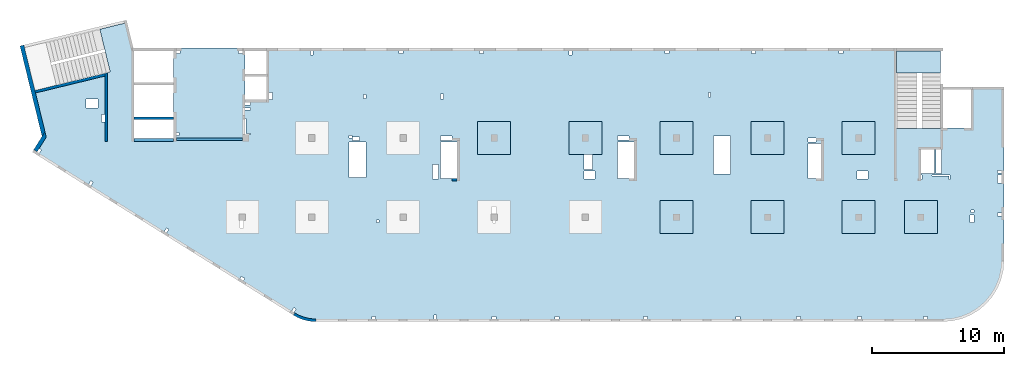
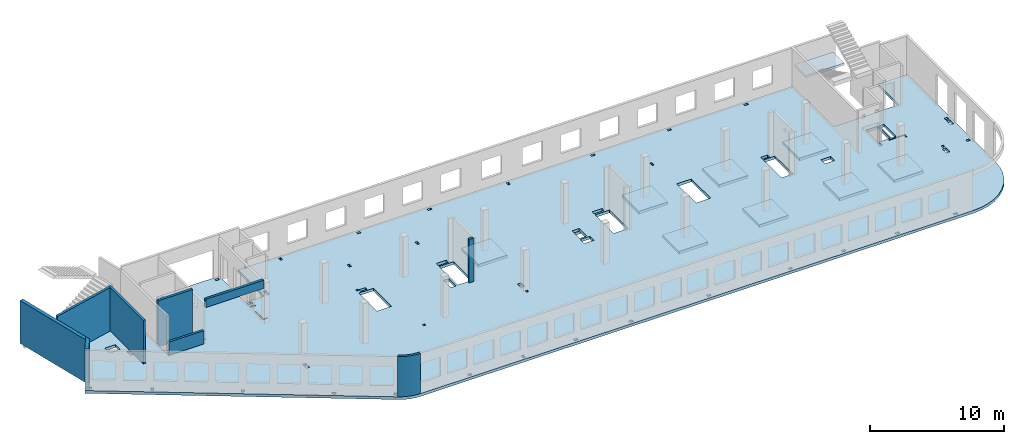
# One storey, part 2 of 6: 11 slabs, 9 walls.
"""IFC4 building model written with IfcOpenShell, lengths in millimetres."""

import ifcopenshell
import ifcopenshell.guid

model = None  # the IFC model being written
_history = None  # IfcOwnerHistory: only IFC2X3 demands one
_inside = {}  # id of a spatial element -> (the spatial element, [elements in it])
_under = {}  # id of a project, library or spatial element -> (it, [spatial elements below it])
_declared = {}  # id of a project -> (the project, [libraries it declares])
_typed = {}  # id of a type object -> (the type object, [elements of that type])
_made_of = {}  # id of a material, layer set ... -> (it, [elements and type objects made of it])


def new_model(schema):
    """Start an empty IFC model of exactly this schema.

    Asked for "IFC4X3", IfcOpenShell would pick the latest addendum, in which some entities
    have other attributes; the version numbers below select the first issue.
    IFC2X3 requires an IfcOwnerHistory on every rooted entity: one is made here for all.
    """
    global model, _history
    if schema == "IFC4X3":
        model = ifcopenshell.file(schema_version=(4, 3, 0, 0))
    else:
        model = ifcopenshell.file(schema=schema)
    _inside.clear()
    _under.clear()
    _declared.clear()
    _typed.clear()
    _made_of.clear()
    _history = None
    if model.schema == "IFC2X3":
        org = make("IfcOrganization", Name="unknown")
        user = make(
            "IfcPersonAndOrganization",
            ThePerson=make("IfcPerson", FamilyName="unknown"),
            TheOrganization=org,
        )
        app = make(
            "IfcApplication",
            ApplicationDeveloper=org,
            Version="unknown",
            ApplicationFullName="unknown",
            ApplicationIdentifier="unknown",
        )
        _history = make(
            "IfcOwnerHistory",
            OwningUser=user,
            OwningApplication=app,
            ChangeAction="ADDED",
            CreationDate=0,
        )
    return model


def make(cls, **values):
    """One entity of the class cls with the attributes given. An attribute that is None is left unset."""
    return model.create_entity(
        cls, **{name: value for name, value in values.items() if value is not None}
    )


def entity(cls, *values):
    """Any entity or typed value of the class cls, its attributes in the order of the schema. None: left unset."""
    e = model.create_entity(cls)
    for i, value in enumerate(values):
        if value is not None:
            e[i] = value
    return e


def rooted(cls, **values):
    """An entity with a GlobalId (a new one), such as an element, a storey or a relation."""
    return make(cls, GlobalId=ifcopenshell.guid.new(), OwnerHistory=_history, **values)


def si_unit(unit_type, name, prefix=None):
    """IfcSIUnit, for example si_unit("LENGTHUNIT", "METRE", prefix="MILLI")."""
    return make("IfcSIUnit", UnitType=unit_type, Prefix=prefix, Name=name)


def converted_unit(unit_type, name, factor, base, dimensions=None, offset=None):
    """IfcConversionBasedUnit, such as the inch: factor (a typed value) times the base unit."""
    return make(
        "IfcConversionBasedUnit"
        if offset is None
        else "IfcConversionBasedUnitWithOffset",
        ConversionOffset=offset,
        Dimensions=None
        if dimensions is None
        else entity("IfcDimensionalExponents", *dimensions),
        UnitType=unit_type,
        Name=name,
        ConversionFactor=make(
            "IfcMeasureWithUnit", ValueComponent=factor, UnitComponent=base
        ),
    )


def derived_unit(unit_type, elements):
    """IfcDerivedUnit: a product of units, each with its exponent."""
    return make(
        "IfcDerivedUnit",
        Elements=[
            make("IfcDerivedUnitElement", Unit=unit, Exponent=power)
            for unit, power in elements
        ],
        UnitType=unit_type,
    )


def assignment(units):
    """IfcUnitAssignment: the units of a project."""
    return None if units is None else make("IfcUnitAssignment", Units=units)


def point(xyz):
    """IfcCartesianPoint."""
    return None if xyz is None else make("IfcCartesianPoint", Coordinates=xyz)


def direction(xyz):
    """IfcDirection."""
    return None if xyz is None else make("IfcDirection", DirectionRatios=xyz)


def frame(location, z_axis=None, x_axis=None):
    """IfcAxis2Placement3D, a coordinate frame: its origin and axes. An axis left out is left unset."""
    return make(
        "IfcAxis2Placement3D",
        Location=point(location),
        Axis=direction(z_axis),
        RefDirection=direction(x_axis),
    )


def origin():
    """The frame at (0, 0, 0) with its axes left unset."""
    return frame((0.0, 0.0, 0.0))


def place(relative_to, where):
    """IfcLocalPlacement: puts the frame where relative to a parent placement (None: the world)."""
    return make(
        "IfcLocalPlacement", PlacementRelTo=relative_to, RelativePlacement=where
    )


def context(
    kind, dimensions, precision=None, world=None, true_north=None, identifier=None
):
    """IfcGeometricRepresentationContext, for example the 3D "Model" context."""
    return make(
        "IfcGeometricRepresentationContext",
        ContextIdentifier=identifier,
        ContextType=kind,
        CoordinateSpaceDimension=dimensions,
        Precision=precision,
        WorldCoordinateSystem=world,
        TrueNorth=true_north,
    )


def subcontext(parent, identifier, kind, view, scale=None):
    """IfcGeometricRepresentationSubContext, for example "Body" below "Model"."""
    return make(
        "IfcGeometricRepresentationSubContext",
        ContextIdentifier=identifier,
        ContextType=kind,
        ParentContext=parent,
        TargetScale=scale,
        TargetView=view,
    )


def project(units=None, contexts=None):
    """IfcProject with its units and contexts."""
    return rooted(
        "IfcProject",
        Name="project",
        RepresentationContexts=contexts,
        UnitsInContext=assignment(units),
    )


def spatial(cls, under=None, at=None, **own):
    """A site, building, storey or space (cls), placed at a placement, below another one or the project."""
    s = rooted(cls, ObjectPlacement=at, **own)
    if under is not None:
        _under.setdefault(under.id(), (under, []))[1].append(s)
    return s


def point_list(points):
    """IfcCartesianPointList2D or 3D."""
    cls = (
        "IfcCartesianPointList2D" if len(points[0]) == 2 else "IfcCartesianPointList3D"
    )
    return make(cls, CoordList=points)


def indexed_curve(points, segments=None, self_intersect=None):
    """IfcIndexedPolyCurve: lines and arcs through numbered points (the first is 1)."""
    return make(
        "IfcIndexedPolyCurve",
        Points=point_list(points),
        Segments=segments,
        SelfIntersect=self_intersect,
    )


def outline(outer, holes=None, kind="AREA"):
    """IfcArbitraryClosedProfileDef: a profile drawn as a closed curve; with holes, ...WithVoids."""
    if holes is None:
        return make("IfcArbitraryClosedProfileDef", ProfileType=kind, OuterCurve=outer)
    return make(
        "IfcArbitraryProfileDefWithVoids",
        ProfileType=kind,
        OuterCurve=outer,
        InnerCurves=holes,
    )


def extrude(swept, where, along, depth):
    """IfcExtrudedAreaSolid: the profile swept, set in the frame where, extruded along a direction by depth."""
    return make(
        "IfcExtrudedAreaSolid",
        SweptArea=swept,
        Position=where,
        ExtrudedDirection=direction(along),
        Depth=depth,
    )


def shape(context_of_items, identifier, shape_type, items):
    """IfcShapeRepresentation: the items that make up one representation, for example the "Body"."""
    return make(
        "IfcShapeRepresentation",
        ContextOfItems=context_of_items,
        RepresentationIdentifier=identifier,
        RepresentationType=shape_type,
        Items=items,
    )


def material(Name=None, Category=None):
    """IfcMaterial."""
    return make("IfcMaterial", Name=Name, Category=Category)


def made_of(thing, what):
    """Note that an element or type object is made of a material, layer set ...; save() writes the relation."""
    if what is not None:
        _made_of.setdefault(what.id(), (what, []))[1].append(thing)
    return thing


def type_object(cls, material=None, **own):
    """A type object (cls), such as IfcWallType, which elements share."""
    return made_of(rooted(cls, **own), material)


def element(
    cls,
    number,
    at=None,
    inside=None,
    cuts=None,
    type_object=None,
    material=None,
    context=None,
    identifier="Body",
    shape_type=None,
    held_by="IfcProductDefinitionShape",
    body=None,
    shapes=None,
    **own,
):
    """One element of the class cls, such as IfcWall. Its Tag is "e" and its number.

    at: its placement. inside: the storey or other place that contains it. cuts: it is an
    opening in that element (IfcRelVoidsElement). A single representation is given by context,
    identifier, shape_type and body (its items); several are given by shapes. held_by: the class
    of the entity that holds the representations. save() writes the other relations.
    """
    e = rooted(cls, Tag="e%d" % number, ObjectPlacement=at, **own)
    if body is not None:
        shapes = [shape(context, identifier, shape_type, body)]
    if shapes is not None:
        e.Representation = make(held_by, Representations=shapes)
    if inside is not None:
        _inside.setdefault(inside.id(), (inside, []))[1].append(e)
    if cuts is not None:
        rooted(
            "IfcRelVoidsElement", RelatingBuildingElement=cuts, RelatedOpeningElement=e
        )
    if type_object is not None:
        _typed.setdefault(type_object.id(), (type_object, []))[1].append(e)
    return made_of(e, material)


def aggregate(whole, parts):
    """IfcRelAggregates: a whole, such as a stair, and the parts it consists of."""
    return rooted("IfcRelAggregates", RelatingObject=whole, RelatedObjects=parts)


def save(model, path):
    """Write the relations noted so far, then the file.

    IfcRelAggregates (storeys below a building ...), IfcRelContainedInSpatialStructure (elements
    in a storey), IfcRelDefinesByType, IfcRelAssociatesMaterial and IfcRelDeclares: one each for
    every whole, place, type object, material and project.
    """
    for whole, parts in _under.values():
        aggregate(whole, parts)
    for where, things in _inside.values():
        rooted(
            "IfcRelContainedInSpatialStructure",
            RelatedElements=things,
            RelatingStructure=where,
        )
    for kind, things in _typed.values():
        rooted("IfcRelDefinesByType", RelatedObjects=things, RelatingType=kind)
    for what, things in _made_of.values():
        rooted("IfcRelAssociatesMaterial", RelatedObjects=things, RelatingMaterial=what)
    for by, libraries in _declared.values():
        rooted("IfcRelDeclares", RelatingContext=by, RelatedDefinitions=libraries)
    model.write(path)


model = new_model("IFC4")

# Units and contexts
model_context = context("Model", 3, precision=0.01, world=origin(), true_north=direction((6.12303176911189e-17, 1.0)))
plan_context = context("Plan", 3, precision=0.01, world=origin(), true_north=direction((6.12303176911189e-17, 1.0)))
body_context = subcontext(model_context, "Body", "Model", "MODEL_VIEW")
ifc_project = project(units=[si_unit("LENGTHUNIT", "METRE", prefix="MILLI"), si_unit("AREAUNIT", "SQUARE_METRE"), si_unit("VOLUMEUNIT", "CUBIC_METRE"), converted_unit("PLANEANGLEUNIT", "DEGREE", entity("IfcRatioMeasure", 0.0174532925199433), si_unit("PLANEANGLEUNIT", "RADIAN"), dimensions=[0, 0, 0, 0, 0, 0, 0]), si_unit("MASSUNIT", "GRAM", prefix="KILO"), derived_unit("MASSDENSITYUNIT", [(si_unit("MASSUNIT", "GRAM", prefix="KILO"), 1), (si_unit("LENGTHUNIT", "METRE"), -3)]), derived_unit("MOMENTOFINERTIAUNIT", [(si_unit("LENGTHUNIT", "METRE"), 4)]), si_unit("TIMEUNIT", "SECOND"), si_unit("FREQUENCYUNIT", "HERTZ"), si_unit("THERMODYNAMICTEMPERATUREUNIT", "DEGREE_CELSIUS"), derived_unit("THERMALTRANSMITTANCEUNIT", [(si_unit("MASSUNIT", "GRAM", prefix="KILO"), 1), (si_unit("THERMODYNAMICTEMPERATUREUNIT", "KELVIN"), -1), (si_unit("TIMEUNIT", "SECOND"), -3)]), derived_unit("VOLUMETRICFLOWRATEUNIT", [(si_unit("LENGTHUNIT", "METRE"), 3), (si_unit("TIMEUNIT", "SECOND"), -1)]), derived_unit("MASSFLOWRATEUNIT", [(si_unit("MASSUNIT", "GRAM", prefix="KILO"), 1), (si_unit("TIMEUNIT", "SECOND"), -1)]), derived_unit("ROTATIONALFREQUENCYUNIT", [(si_unit("TIMEUNIT", "SECOND"), -1)]), si_unit("ELECTRICCURRENTUNIT", "AMPERE"), si_unit("ELECTRICVOLTAGEUNIT", "VOLT"), si_unit("POWERUNIT", "WATT"), si_unit("FORCEUNIT", "NEWTON", prefix="KILO"), si_unit("ILLUMINANCEUNIT", "LUX"), si_unit("LUMINOUSFLUXUNIT", "LUMEN"), si_unit("LUMINOUSINTENSITYUNIT", "CANDELA"), derived_unit("USERDEFINED", [(si_unit("MASSUNIT", "GRAM", prefix="KILO"), -1), (si_unit("LENGTHUNIT", "METRE"), -2), (si_unit("TIMEUNIT", "SECOND"), 3), (si_unit("LUMINOUSFLUXUNIT", "LUMEN"), 1)]), derived_unit("LINEARVELOCITYUNIT", [(si_unit("LENGTHUNIT", "METRE"), 1), (si_unit("TIMEUNIT", "SECOND"), -1)]), si_unit("PRESSUREUNIT", "PASCAL"), derived_unit("USERDEFINED", [(si_unit("LENGTHUNIT", "METRE"), -2), (si_unit("MASSUNIT", "GRAM", prefix="KILO"), 1), (si_unit("TIMEUNIT", "SECOND"), -2)]), derived_unit("LINEARFORCEUNIT", [(si_unit("MASSUNIT", "GRAM", prefix="KILO"), 1), (si_unit("LENGTHUNIT", "METRE"), 1), (si_unit("TIMEUNIT", "SECOND"), -2), (si_unit("LENGTHUNIT", "METRE"), -1)]), derived_unit("PLANARFORCEUNIT", [(si_unit("MASSUNIT", "GRAM", prefix="KILO"), 1), (si_unit("LENGTHUNIT", "METRE"), 1), (si_unit("TIMEUNIT", "SECOND"), -2), (si_unit("LENGTHUNIT", "METRE"), -2)])], contexts=[model_context, plan_context])

# Site, building, storey
site_placement = place(None, origin())
site = spatial("IfcSite", under=ifc_project, at=site_placement, CompositionType="ELEMENT")
building_placement = place(site_placement, origin())
building = spatial("IfcBuilding", under=site, at=building_placement, CompositionType="ELEMENT")
storey_placement = place(building_placement, frame((0.0, 0.0, 12000.0)))
storey = spatial("IfcBuildingStorey", under=building, at=storey_placement, Name="04", CompositionType="ELEMENT", Elevation=12000.0)

# Slabs
ifc_material = material()
slab_type_1 = type_object("IfcSlabType", Name=":ADSK_ 25_250", PredefinedType="FLOOR", material=ifc_material)
placement = place(storey_placement, origin())
element("IfcSlab", 1, at=placement, inside=storey, type_object=slab_type_1, material=ifc_material, Name=":ADSK_ 25_250", ObjectType=":ADSK_ 25_250", PredefinedType="FLOOR", context=body_context, shape_type="SweptSolid", body=[
    extrude(outline(indexed_curve([(-11615.3456191022, -15866.2384672249), (-11461.2227621515, -15956.6617307079), (-11302.2940263976, -16038.3432987954), (-11139.0547290428, -16111.0286027615), (-10972.0136215827, -16174.4911116315), (-10801.6913042325, -16228.5330381886), (-10628.6186034238, -16272.985955397), (-10453.3349174317, -16307.7113213217), (-10276.3865352866, -16332.6009109081), (-10098.3249342096, -16347.5771532763), (-9919.70506087959, -16352.5933734784), (37585.2949391216, -16352.5933734786), (38304.8933503634, -16295.9597502856), (39006.7728605103, -16127.4533884657), (39673.6508666178, -15851.2234738877), (40289.1066189344, -15474.0717038028), (40837.9855542575, -15005.2848064856), (41306.7724515748, -14456.4058711625), (41683.9242216596, -13840.9501188459), (41960.1541362377, -13174.0721127383), (42128.6604980575, -12472.1926025915), (42185.2941212505, -11752.5941913496), (42185.2941212505, 1417.40662652148), (39685.2941212505, 1417.40662652149), (39685.2941212505, -1682.59337347851), (37385.2949391216, -1682.59337347851), (37385.2949391216, -1722.59337347848), (34045.2949391217, -1722.59337347847), (34045.2949391217, 4347.4072658887), (-13659.7050608784, 4347.40726588886), (-13659.7050608784, 447.406626521855), (-15284.7050608784, 447.406626521859), (-15284.7050608784, 4347.40726588869), (-20684.7050608784, 4347.40726588871), (-20684.7050608784, -2502.5933734781), (-23684.7050608784, -2502.59337347809), (-23684.7050608784, 4347.40726588869), (-23734.0606732206, 4347.40726588869), (-24254.10794231, 6480.84192351009), (-24448.4183539383, 6433.47670491202), (-24401.0531353402, 6239.16629328373), (-26276.1486075532, 5782.09193381237), (-25485.1529405355, 2537.12235056864), (-31479.6214345329, 1075.90723492907), (-30648.3195083992, -2334.4141830962), (-31384.8454167592, -3513.12502953493), (-11615.3456191022, -15866.2384672249)], self_intersect=False), holes=[indexed_curve([(-26424.7050608784, -192.593373478052), (-27324.7050608784, -192.593373478052), (-27324.7050608784, 507.406626521949), (-26424.7050608784, 507.406626521947), (-26424.7050608784, -192.593373478052)], self_intersect=False), indexed_curve([(-25884.7050608784, -667.593373478048), (-25884.7050608784, -1227.59337347805), (-26134.7050608784, -1227.59337347805), (-26134.7050608784, -667.593373478048), (-25884.7050608784, -667.593373478048)], self_intersect=False), indexed_curve([(-30865.4736804199, -3248.07220556975), (-30695.8631316644, -3354.05457085215), (-30854.836679588, -3608.47039398543), (-31024.4472283436, -3502.48802870303), (-30865.4736804199, -3248.07220556975)], self_intersect=False), indexed_curve([(-26955.9505316053, -5690.96572532919), (-26786.3399828498, -5796.94809061159), (-26945.3135307734, -6051.36391374487), (-27114.9240795289, -5945.38154846246), (-26955.9505316053, -5690.96572532919)], self_intersect=False), indexed_curve([(-21223.1139836689, -9273.16967187448), (-21053.5034349134, -9379.15203715688), (-21212.476982837, -9633.56786029016), (-21382.0875315925, -9527.58549500775), (-21223.1139836689, -9273.16967187448)], self_intersect=False), indexed_curve([(-15551.7491458115, -12934.8797745334), (-15297.3333226782, -13093.853322457), (-15403.3156879606, -13263.4638712125), (-15657.7315110939, -13104.4903232889), (-15551.7491458115, -12934.8797745334)], self_intersect=False), indexed_curve([(-11580.7542869179, -15298.2671381792), (-11411.1437381624, -15404.2495034616), (-11570.117286086, -15658.6653265949), (-11739.7278348415, -15552.6829613125), (-11580.7542869179, -15298.2671381792)], self_intersect=False), indexed_curve([(-5384.7050608784, -16152.5933734782), (-5684.7050608784, -16152.5933734782), (-5684.7050608784, -15952.5933734782), (-5384.7050608784, -15952.5933734782), (-5384.7050608784, -16152.5933734782)], self_intersect=False), indexed_curve([(-789.705060878393, -16152.5933734782), (-989.705060878395, -16152.5933734782), (-989.705060878386, -15852.5933734782), (-789.705060878388, -15852.5933734782), (-789.705060878393, -16152.5933734782)], self_intersect=False), indexed_curve([(3735.29493912161, -16152.5933734782), (3435.29493912161, -16152.5933734782), (3435.29493912161, -15952.5933734782), (3735.29493912161, -15952.5933734782), (3735.29493912161, -16152.5933734782)], self_intersect=False), indexed_curve([(8485.29493912161, -16152.5933734783), (8185.29493912161, -16152.5933734782), (8185.29493912161, -15952.5933734782), (8485.29493912161, -15952.5933734783), (8485.29493912161, -16152.5933734783)], self_intersect=False), indexed_curve([(15185.2949391216, -16152.5933734783), (14885.2949391216, -16152.5933734782), (14885.2949391216, -15952.5933734783), (15185.2949391216, -15952.5933734783), (15185.2949391216, -16152.5933734783)], self_intersect=False), indexed_curve([(22185.2949391216, -16152.5933734783), (21885.2949391216, -16152.5933734783), (21885.2949391216, -15952.5933734783), (22185.2949391216, -15952.5933734783), (22185.2949391216, -16152.5933734783)], self_intersect=False), indexed_curve([(26785.2949391216, -16152.5933734783), (26485.2949391216, -16152.5933734783), (26485.2949391216, -15952.5933734783), (26785.2949391216, -15952.5933734783), (26785.2949391216, -16152.5933734783)], self_intersect=False), indexed_curve([(31385.2949391216, -16152.5933734783), (31085.2949391216, -16152.5933734783), (31085.2949391216, -15952.5933734783), (31385.2949391216, -15952.5933734783), (31385.2949391216, -16152.5933734783)], self_intersect=False), indexed_curve([(36385.2949391216, -16152.5933734783), (36085.2949391216, -16152.5933734783), (36085.2949391216, -15952.5933734783), (36385.2949391216, -15952.5933734783), (36385.2949391216, -16152.5933734783)], self_intersect=False), indexed_curve([(-20184.7050608784, 4147.4072658887), (-20184.7050608784, 3947.4072658887), (-20484.7050608784, 3947.40726588869), (-20484.7050608784, 4147.4072658887), (-20184.7050608784, 4147.4072658887)], self_intersect=False), indexed_curve([(-20284.7050608784, -2252.59337347809), (-20484.7050608784, -2252.59337347809), (-20484.7050608784, -2052.59337347809), (-20284.7050608784, -2052.59337347809), (-20284.7050608784, -2252.59337347809)], self_intersect=False), indexed_curve([(-15784.7050608784, 4147.4072658887), (-15484.7050608784, 4147.4072658887), (-15484.7050608784, 3947.4072658887), (-15784.7050608784, 3947.4072658887), (-15784.7050608784, 4147.4072658887)], self_intersect=False), indexed_curve([(-14854.7050608784, 247.406626521861), (-14854.7050608784, 47.4066265218589), (-15284.7050608784, 47.4066265218589), (-15284.7050608784, 247.406626521859), (-14854.7050608784, 247.406626521861)], self_intersect=False), indexed_curve([(-14854.7050608784, -177.593373478142), (-14854.7050608784, -337.59337347814), (-15284.7050608784, -337.59337347814), (-15284.7050608784, -177.593373478142), (-14854.7050608784, -177.593373478142)], self_intersect=False), indexed_curve([(-15284.7050608784, -2182.59337347814), (-15284.7050608784, -992.593373478139), (-15204.7050608784, -992.593373478139), (-15204.7050608784, -2102.59337347814), (-14864.7050608784, -2102.59337347814), (-14864.7050608784, -2182.59337347814), (-15284.7050608784, -2182.59337347814)], self_intersect=False), indexed_curve([(-13209.7050608784, 447.406626521855), (-13459.7050608784, 447.406626521855), (-13459.7050608784, 1007.40662652186), (-13209.7050608784, 1007.40662652186), (-13209.7050608784, 447.406626521855)], self_intersect=False), indexed_curve([(-10314.7050608784, 4147.4072658887), (-10214.7050608784, 4147.4072658887), (-10114.7050608784, 4147.40662652183), (-10114.7050608784, 3847.40726588869), (-10314.7050608784, 3847.40726588869), (-10314.7050608784, 4147.4072658887)], self_intersect=False), indexed_curve([(-3614.70506087836, 4147.40662652179), (-3314.70506087836, 4147.40662652179), (-3314.70506087836, 3947.40662652179), (-3614.70506087836, 3947.40662652179), (-3614.70506087836, 4147.40662652179)], self_intersect=False), indexed_curve([(2460.29493912165, 4147.40662652177), (2760.29493912165, 4147.40662652177), (2760.29493912164, 3947.40662652177), (2460.29493912164, 3947.40662652176), (2460.29493912165, 4147.40662652177)], self_intersect=False), indexed_curve([(16510.2949391216, 4147.40662652173), (16810.2949391216, 4147.40662652172), (16810.2949391216, 3947.40662652171), (16510.2949391216, 3947.40662652172), (16510.2949391216, 4147.40662652173)], self_intersect=False), indexed_curve([(9260.29493912165, 4147.4066265217), (9460.29493912165, 4147.4066265217), (9460.29493912166, 3847.4066265217), (9260.29493912165, 3847.4066265217), (9260.29493912165, 4147.4066265217)], self_intersect=False), indexed_curve([(23085.2949391216, 4147.40662652169), (23385.2949391216, 4147.40662652169), (23385.2949391216, 3947.4066265217), (23085.2949391216, 3947.4066265217), (23085.2949391216, 4147.40662652169)], self_intersect=False), indexed_curve([(29685.2949391216, 4147.40662652168), (29985.2949391216, 4147.40662652167), (29985.2949391216, 3947.40662652167), (29685.2949391216, 3947.40662652167), (29685.2949391216, 4147.40662652168)], self_intersect=False), indexed_curve([(-6114.70506087836, 847.407265888692), (-6114.70506087836, 527.407265888689), (-6314.70506087837, 527.407265888691), (-6314.70506087837, 847.407265888695), (-6114.70506087836, 847.407265888692)], self_intersect=False), indexed_curve([(-264.705060878365, 867.407265888811), (-264.70506087836, 507.407265888813), (-464.705060878358, 507.407265888813), (-464.705060878358, 867.407265888811), (-264.705060878365, 867.407265888811)], self_intersect=False), indexed_curve([(19975.2949391216, 997.407265888704), (19975.2949391216, 647.407265888701), (19825.2949391216, 647.407265888701), (19825.2949391216, 997.407265888704), (19975.2949391216, 997.407265888704)], self_intersect=False), indexed_curve([(37055.2949391217, -5127.59337347849), (37055.2949391217, -3322.59337347848), (37385.2949391216, -3322.59337347849), (37445.2949391217, -3322.59337347849), (37445.2949391217, -5127.59337347849), (37055.2949391217, -5127.59337347849)], self_intersect=False), indexed_curve([(35975.2949391217, -5247.59337347849), (35975.2949391217, -5587.59337347849), (35895.2949391217, -5587.59337347849), (35895.2949391217, -5247.59337347849), (35975.2949391217, -5247.59337347849)], self_intersect=False), indexed_curve([(38095.2949391216, -5247.59337347848), (38095.2949391216, -5587.59337347848), (38015.2949391216, -5587.59337347849), (38015.2949391216, -5327.59337347848), (36715.2949391216, -5327.59337347848), (36715.2949391216, -5247.59337347849), (38095.2949391216, -5247.59337347848)], self_intersect=False), indexed_curve([(41685.2941212505, -8342.59337347853), (41685.2941212505, -8142.59337347853), (41985.2941212505, -8142.59337347853), (41985.2941212505, -8342.59337347853), (41685.2941212505, -8342.59337347853)], self_intersect=False), indexed_curve([(41685.2941212505, -5102.59337347853), (41685.2941212505, -4902.59337347852), (41985.2941212505, -4902.59337347853), (41985.2941212505, -5102.59337347853), (41685.2941212505, -5102.59337347853)], self_intersect=False), indexed_curve([(41685.2941212505, -5867.59337347854), (41685.2941212505, -5267.59337347853), (41985.2941212505, -5267.59337347854), (41985.2941212505, -5867.59337347854), (41685.2941212505, -5867.59337347854)], self_intersect=False), indexed_curve([(39895.2941212505, -8272.5933734785), (39895.2941212505, -8852.59337347852), (39595.2941212505, -8852.59337347852), (39595.2941212505, -8272.59337347851), (39895.2941212505, -8272.5933734785)], self_intersect=False), indexed_curve([(39905.2941212505, -7892.59337347851), (39905.2941212505, -8092.59337347851), (39705.2941212505, -8092.59337347851), (39705.2941212505, -7892.5933734785), (39905.2941212505, -7892.59337347851)], self_intersect=False), indexed_curve([(31900.2949391216, -4967.59337347845), (31900.2949391216, -5567.59337347845), (31070.2949391216, -5567.59337347845), (31070.2949391216, -4967.59337347845), (31900.2949391216, -4967.59337347845)], self_intersect=False), indexed_curve([(27345.2949391216, -5527.59337347843), (27345.2949391216, -2857.59337347842), (28345.2949391217, -2857.59337347842), (28345.2949391217, -5527.59337347844), (27345.2949391216, -5527.59337347843)], self_intersect=False), indexed_curve([(27345.2949391216, -2452.59337347842), (27945.2949391216, -2452.59337347842), (27945.2949391216, -2737.59337347842), (27345.2949391216, -2737.59337347842), (27345.2949391216, -2452.59337347842)], self_intersect=False), indexed_curve([(21465.2949391216, -2317.59337347838), (21465.2949391216, -5177.59337347839), (20205.2949391216, -5177.59337347839), (20205.2949391216, -2317.59337347838), (21465.2949391216, -2317.59337347838)], self_intersect=False), indexed_curve([(12925.2949391216, -5527.59322391854), (12925.2949391216, -2752.59322391854), (14185.2949391216, -2752.59322391854), (14185.2949391216, -5527.59322391853), (12925.2949391216, -5527.59322391854)], self_intersect=False), indexed_curve([(12925.2949391216, -2602.59337347834), (12925.2949391216, -2312.59337347833), (13785.2949391216, -2312.59337347833), (13785.2949391216, -2602.59337347834), (12925.2949391216, -2602.59337347834)], self_intersect=False), indexed_curve([(10395.2949391217, -3702.59337347839), (10485.2949391216, -3702.59337347838), (11015.2949391216, -3702.59337347839), (11015.2949391216, -4822.59337347839), (10395.2949391217, -4822.59337347839), (10395.2949391217, -3702.59337347839)], self_intersect=False), indexed_curve([(10370.2949391216, -4967.59337347839), (11200.2949391216, -4967.59337347839), (11200.2949391216, -5567.59337347838), (10370.2949391216, -5567.59337347839), (10370.2949391216, -4967.59337347839)], self_intersect=False), indexed_curve([(3485.29493912162, -8702.59337347826), (3585.29493912162, -8702.59337347826), (3685.29493912163, -8702.59337347826), (3685.29493912163, -8902.59337347827), (3485.29493912163, -8902.59337347827), (3485.29493912162, -8702.59337347826)], self_intersect=False), indexed_curve([(3405.29493912162, -8162.59337347827), (3405.29493912162, -7652.59337347826), (3735.29493912162, -7652.59337347827), (3735.29493912162, -8162.59337347826), (3405.29493912162, -8162.59337347827)], self_intersect=False), indexed_curve([(-474.705060878365, -5527.5932239185), (-474.705060878365, -2752.5932239185), (785.29493912163, -2752.5932239185), (785.294939121635, -5527.59322391849), (-474.705060878365, -5527.5932239185)], self_intersect=False), indexed_curve([(-474.705060878365, -2312.59337347824), (385.29493912163, -2312.59337347824), (385.294939121626, -2632.59337347824), (-474.705060878369, -2632.59337347824), (-474.705060878365, -2312.59337347824)], self_intersect=False), indexed_curve([(-1094.70506087836, -5567.5932239185), (-1094.70506087837, -4477.5932239185), (-634.705060878363, -4477.5932239185), (-634.705060878363, -5567.5932239185), (-1094.70506087836, -5567.5932239185)], self_intersect=False), indexed_curve([(-5134.70506087838, -8662.5933734782), (-5134.70506087839, -8862.5933734782), (-5334.70506087839, -8862.5933734782), (-5334.70506087839, -8662.5933734782), (-5134.70506087838, -8662.5933734782)], self_intersect=False), indexed_curve([(-15644.7050608784, -8702.59337347814), (-15484.7050608784, -8702.59337347813), (-15394.7050608784, -8702.59337347813), (-15394.7050608784, -9262.59337347813), (-15644.7050608784, -9262.59337347814), (-15644.7050608784, -8702.59337347814)], self_intersect=False), indexed_curve([(-6134.70506087837, -2752.59337347818), (-6134.70506087837, -5462.59337347818), (-7394.70506087837, -5462.59337347818), (-7394.70506087837, -2752.59337347818), (-6134.70506087837, -2752.59337347818)], self_intersect=False), indexed_curve([(-7194.70506087837, -2462.59337347819), (-7394.70506087837, -2462.59337347819), (-7394.70506087837, -2272.59337347818), (-7194.70506087837, -2272.59337347818), (-7194.70506087837, -2462.59337347819)], self_intersect=False), indexed_curve([(-6594.70506087837, -2632.59337347819), (-7154.70506087837, -2632.59337347819), (-7154.70506087837, -2382.5933734782), (-6594.70506087837, -2382.5933734782), (-6594.70506087837, -2632.59337347819)], self_intersect=False), indexed_curve([(36935.2949391217, -3322.59337347849), (36935.2949391217, -5127.59337347849), (35895.2949391217, -5127.59337347849), (35895.2949391217, -3322.59337347849), (36935.2949391217, -3322.59337347849)], self_intersect=False)]), frame((31384.71, 16152.59, -400.0)), (0.0, 0.0, 1.0), 249.999999999999),
])
slab_type_2 = type_object("IfcSlabType", Name=":ADSK_ 25_250", PredefinedType="FLOOR", material=ifc_material)
element("IfcSlab", 2, at=placement, inside=storey, type_object=slab_type_2, material=ifc_material, Name=":ADSK_ 25_250", ObjectType=":ADSK_ 25_250", PredefinedType="FLOOR", context=body_context, shape_type="SweptSolid", body=[
    extrude(outline(indexed_curve([(-1250.0, -1250.0), (1250.0, -1250.0), (1250.0, 1250.0), (-1250.0, 1250.0), (-1250.0, -1250.0)], self_intersect=False)), frame((48770.0, 7700.0, -400.0), z_axis=(0.0, 0.0, -1.0), x_axis=(0.0, 1.0, 0.0)), (0.0, 0.0, 1.0), 249.999999999999),
])
slab_type_3 = type_object("IfcSlabType", Name=":ADSK_ 25_250", PredefinedType="FLOOR", material=ifc_material)
element("IfcSlab", 3, at=placement, inside=storey, type_object=slab_type_3, material=ifc_material, Name=":ADSK_ 25_250", ObjectType=":ADSK_ 25_250", PredefinedType="FLOOR", context=body_context, shape_type="SweptSolid", body=[
    extrude(outline(indexed_curve([(-1250.0, -1249.99999999999), (1250.0, -1249.99999999999), (1250.0, 1250.00000000001), (-1250.0, 1250.00000000001), (-1250.0, -1249.99999999999)], self_intersect=False)), frame((55670.0, 7700.0, -400.0), z_axis=(0.0, 0.0, -1.0), x_axis=(0.0, 1.0, 0.0)), (0.0, 0.0, 1.0), 249.999999999999),
])
slab_type_4 = type_object("IfcSlabType", Name=":ADSK_ 25_250", PredefinedType="FLOOR", material=ifc_material)
element("IfcSlab", 4, at=placement, inside=storey, type_object=slab_type_4, material=ifc_material, Name=":ADSK_ 25_250", ObjectType=":ADSK_ 25_250", PredefinedType="FLOOR", context=body_context, shape_type="SweptSolid", body=[
    extrude(outline(indexed_curve([(-1250.0, -1250.0), (1250.0, -1250.0), (1250.0, 1250.0), (-1250.0, 1250.0), (-1250.0, -1250.0)], self_intersect=False)), frame((62570.0, 7700.0, -400.0), z_axis=(0.0, 0.0, -1.0), x_axis=(0.0, 1.0, 0.0)), (0.0, 0.0, 1.0), 249.999999999999),
])
slab_type_5 = type_object("IfcSlabType", Name=":ADSK_ 25_250", PredefinedType="FLOOR", material=ifc_material)
element("IfcSlab", 5, at=placement, inside=storey, type_object=slab_type_5, material=ifc_material, Name=":ADSK_ 25_250", ObjectType=":ADSK_ 25_250", PredefinedType="FLOOR", context=body_context, shape_type="SweptSolid", body=[
    extrude(outline(indexed_curve([(-1250.0, -1249.99999999999), (1250.0, -1249.99999999999), (1250.0, 1250.00000000001), (-1250.0, 1250.00000000001), (-1250.0, -1249.99999999999)], self_intersect=False)), frame((67270.0, 7700.0, -400.0), z_axis=(0.0, 0.0, -1.0), x_axis=(0.0, 1.0, 0.0)), (0.0, 0.0, 1.0), 249.999999999999),
])
slab_type_6 = type_object("IfcSlabType", Name=":ADSK_ 25_250", PredefinedType="FLOOR", material=ifc_material)
element("IfcSlab", 6, at=placement, inside=storey, type_object=slab_type_6, material=ifc_material, Name=":ADSK_ 25_250", ObjectType=":ADSK_ 25_250", PredefinedType="FLOOR", context=body_context, shape_type="SweptSolid", body=[
    extrude(outline(indexed_curve([(-1250.0, -1250.0), (1250.0, -1250.0), (1250.0, 1250.0), (-1250.0, 1250.0), (-1250.0, -1250.0)], self_intersect=False)), frame((62570.0, 13700.0, -400.0), z_axis=(0.0, 0.0, -1.0), x_axis=(0.0, 1.0, 0.0)), (0.0, 0.0, 1.0), 249.999999999999),
])
slab_type_7 = type_object("IfcSlabType", Name=":ADSK_ 25_250", PredefinedType="FLOOR", material=ifc_material)
element("IfcSlab", 7, at=placement, inside=storey, type_object=slab_type_7, material=ifc_material, Name=":ADSK_ 25_250", ObjectType=":ADSK_ 25_250", PredefinedType="FLOOR", context=body_context, shape_type="SweptSolid", body=[
    extrude(outline(indexed_curve([(-1250.0, -1250.0), (1250.0, -1250.0), (1250.0, 1250.0), (-1250.0, 1250.0), (-1250.0, -1250.0)], self_intersect=False)), frame((55670.0, 13700.0, -400.0), z_axis=(0.0, 0.0, -1.0), x_axis=(0.0, 1.0, 0.0)), (0.0, 0.0, 1.0), 249.999999999999),
])
slab_type_8 = type_object("IfcSlabType", Name=":ADSK_ 25_250", PredefinedType="FLOOR", material=ifc_material)
element("IfcSlab", 8, at=placement, inside=storey, type_object=slab_type_8, material=ifc_material, Name=":ADSK_ 25_250", ObjectType=":ADSK_ 25_250", PredefinedType="FLOOR", context=body_context, shape_type="SweptSolid", body=[
    extrude(outline(indexed_curve([(-1250.0, -1250.0), (1250.0, -1250.0), (1250.0, 1250.0), (-1250.0, 1250.0), (-1250.0, -1250.0)], self_intersect=False)), frame((48770.0, 13700.0, -400.0), z_axis=(0.0, 0.0, -1.0), x_axis=(0.0, 1.0, 0.0)), (0.0, 0.0, 1.0), 249.999999999999),
])
slab_type_9 = type_object("IfcSlabType", Name=":ADSK_ 25_250", PredefinedType="FLOOR", material=ifc_material)
element("IfcSlab", 9, at=placement, inside=storey, type_object=slab_type_9, material=ifc_material, Name=":ADSK_ 25_250", ObjectType=":ADSK_ 25_250", PredefinedType="FLOOR", context=body_context, shape_type="SweptSolid", body=[
    extrude(outline(indexed_curve([(-1250.0, -1250.0), (1250.0, -1250.0), (1250.0, 1250.0), (-1250.0, 1250.0), (-1250.0, -1250.0)], self_intersect=False)), frame((41870.0, 13700.0, -400.0), z_axis=(0.0, 0.0, -1.0), x_axis=(0.0, 1.0, 0.0)), (0.0, 0.0, 1.0), 249.999999999999),
])
slab_type_10 = type_object("IfcSlabType", Name=":ADSK_ 25_250", PredefinedType="FLOOR", material=ifc_material)
element("IfcSlab", 10, at=placement, inside=storey, type_object=slab_type_10, material=ifc_material, Name=":ADSK_ 25_250", ObjectType=":ADSK_ 25_250", PredefinedType="FLOOR", context=body_context, shape_type="SweptSolid", body=[
    extrude(outline(indexed_curve([(-1250.0, -1250.0), (1250.0, -1250.0), (1250.0, 1250.0), (-1250.0, 1250.0), (-1250.0, -1250.0)], self_intersect=False)), frame((34970.0, 13700.0, -400.0), z_axis=(0.0, 0.0, -1.0), x_axis=(0.0, 1.0, 0.0)), (0.0, 0.0, 1.0), 249.999999999999),
])
slab_type_11 = type_object("IfcSlabType", Name=":ADSK_ 25_200", PredefinedType="FLOOR", material=ifc_material)
element("IfcSlab", 11, at=placement, inside=storey, type_object=slab_type_11, material=ifc_material, Name=":ADSK_ 25_200", ObjectType=":ADSK_ 25_200", PredefinedType="FLOOR", context=body_context, shape_type="SweptSolid", body=[
    extrude(outline(indexed_curve([(-834.999999999999, -1670.00000000001), (835.000000000001, -1670.00000000001), (835.000000000001, 1670.00000000002), (-834.999999999999, 1670.00000000002), (-834.999999999999, -1670.00000000001)], self_intersect=False)), frame((67100.0, 19465.0, 1920.0), z_axis=(0.0, 0.0, -1.0), x_axis=(0.0, 1.0, 0.0)), (0.0, 0.0, 1.0), 200.0),
])

# Walls
wall_type_1 = type_object("IfcWallType", Name=":ADSK_ 25_200", PredefinedType="STANDARD")
wall_1_placement = place(storey_placement, frame((19822.35, 371.16, -150.0)))
element("IfcWall", 12, at=wall_1_placement, inside=storey, type_object=wall_type_1, material=ifc_material, Name=":ADSK_ 25_200", ObjectType=":ADSK_ 25_200", PredefinedType="NOTDEFINED", context=body_context, shape_type="SweptSolid", body=[
    extrude(outline(indexed_curve([(1647.48298908956, -371.159642137684), (1479.53495854193, -366.732336838998), (1312.09852486252, -352.905454552832), (1145.69934172072, -329.72240370142), (980.859806418502, -297.255965670987), (818.09741986465, -255.608066320247), (657.923161920899, -204.909455992096), (500.839887220395, -145.319299033065), (347.340746494629, -77.024674109233), (197.907638365059, -0.239986887291593), (53.0096964598414, 84.7937030753815), (-53.0096964598197, -84.7937030753918), (101.553010904459, -175.499182842681), (260.953382356765, -257.405447245706), (424.69099282044, -330.255357933605), (592.251800794088, -393.820208274097), (763.109762144871, -447.900441360165), (936.728481583211, -492.326276503471), (1112.5628966341, -526.958242247616), (1290.06098881835, -551.687614227945), (1468.66551667174, -566.436756503237), (1647.81576516126, -571.159365287708), (1647.48298908956, -371.159642137684)], self_intersect=False)), origin(), (0.0, 0.0, 1.0), 3650.0),
])
wall_2_placement = place(storey_placement, frame((5600.0, 13450.0, -150.0), z_axis=(0.0, 0.0, 1.0), x_axis=(0.0, 1.0, 0.0)))
element("IfcWall", 13, at=wall_2_placement, inside=storey, type_object=wall_type_1, material=ifc_material, Name=":ADSK_ 25_200", ObjectType=":ADSK_ 25_200", PredefinedType="NOTDEFINED", context=body_context, shape_type="SweptSolid", body=[
    extrude(outline(indexed_curve([(5191.05764338749, -100.0), (5142.30552742916, 99.9999999999995), (4936.44934265344, 100.0), (-1.37676332088153e-13, 100.0), (1.37676332088153e-13, -100.0), (5191.05764338749, -100.0)], self_intersect=False)), origin(), (0.0, 0.0, 1.0), 3950.0),
])
wall_3_placement = place(storey_placement, frame((220.24, 17202.38, -150.0), z_axis=(0.0, 0.0, 1.0), x_axis=(0.971552058141473, 0.236826092990337, 0.0)))
element("IfcWall", 14, at=wall_3_placement, inside=storey, type_object=wall_type_1, material=ifc_material, Name=":ADSK_ 25_200", ObjectType=":ADSK_ 25_200", PredefinedType="NOTDEFINED", context=body_context, shape_type="SweptSolid", body=[
    extrude(outline(indexed_curve([(5409.98499256816, -100.000000000001), (5458.73710852649, 100.000000000001), (2.16573425859679e-12, 99.9999999999995), (1.77657888400518e-12, -100.0), (5409.98499256816, -100.000000000001)], self_intersect=False)), origin(), (0.0, 0.0, 1.0), 3950.0),
])
wall_4_placement = place(storey_placement, frame((7700.0, 15200.0, -400.0)))
element("IfcWall", 15, at=wall_4_placement, inside=storey, type_object=wall_type_1, material=ifc_material, Name=":ADSK_ 25_200", ObjectType=":ADSK_ 25_200", PredefinedType="NOTDEFINED", context=body_context, shape_type="SweptSolid", body=[
    extrude(outline(indexed_curve([(3000.0, 99.9999999999989), (-2.88764567812902e-13, 99.9999999999989), (2.88764567812902e-13, -99.9999999999989), (3000.0, -99.9999999999989), (3000.0, 99.9999999999989)], self_intersect=False)), origin(), (0.0, 0.0, 1.0), 4200.0),
])
wall_5_placement = place(storey_placement, frame((32170.0, 10525.0, -150.0), z_axis=(0.0, 0.0, 1.0), x_axis=(-1.0, 0.0, 0.0)))
element("IfcWall", 16, at=wall_5_placement, inside=storey, type_object=wall_type_1, material=ifc_material, Name=":ADSK_ 25_200", ObjectType=":ADSK_ 25_200", PredefinedType="NOTDEFINED", context=body_context, shape_type="SweptSolid", body=[
    extrude(outline(indexed_curve([(399.999999999995, 99.9999999999982), (-3.60955709766131e-13, 99.9999999999989), (3.60955709766131e-13, -99.9999999999989), (399.999999999996, -99.9999999999996), (399.999999999995, 99.9999999999982)], self_intersect=False)), origin(), (0.0, 0.0, 1.0), 3950.0),
])
wall_6_placement = place(storey_placement, frame((10900.0, 13600.0, 3050.0)))
element("IfcWall", 17, at=wall_6_placement, inside=storey, type_object=wall_type_1, material=ifc_material, Name=":ADSK_ 25_200", ObjectType=":ADSK_ 25_200", PredefinedType="NOTDEFINED", context=body_context, shape_type="SweptSolid", body=[
    extrude(outline(indexed_curve([(4999.99925537109, 99.9999999999989), (-3.03202841358267e-13, 99.9999999999989), (3.03202841358267e-13, -99.9999999999989), (4999.99925537109, -99.9999999999989), (4999.99925537109, 99.9999999999989)], self_intersect=False)), origin(), (0.0, 0.0, 1.0), 749.999999999998),
])
wall_7_placement = place(storey_placement, frame((7700.0, 13550.0, -150.0)))
element("IfcWall", 18, at=wall_7_placement, inside=storey, type_object=wall_type_1, material=ifc_material, Name=":ADSK_ 25_200", ObjectType=":ADSK_ 25_200", PredefinedType="NOTDEFINED", context=body_context, shape_type="SweptSolid", body=[
    extrude(outline(indexed_curve([(3000.0, 99.9999999999989), (-2.88764567812902e-13, 99.9999999999989), (2.88764567812902e-13, -99.9999999999989), (3000.0, -99.9999999999989), (3000.0, 99.9999999999989)], self_intersect=False)), origin(), (0.0, 0.0, 1.0), 1200.0),
])
wall_type_2 = type_object("IfcWallType", Name=":ADSK_ 25_300", PredefinedType="STANDARD")
wall_8_placement = place(storey_placement, frame((233.05, 12729.59, -150.0), z_axis=(0.0, 0.0, 1.0), x_axis=(0.529911826412024, 0.848052743777575, 0.0)))
element("IfcWall", 19, at=wall_8_placement, inside=storey, type_object=wall_type_2, material=ifc_material, Name=":ADSK_ 25_300", ObjectType=":ADSK_ 25_300", PredefinedType="NOTDEFINED", context=body_context, shape_type="SweptSolid", body=[
    extrude(outline(indexed_curve([(1316.31557757947, -150.0), (1609.08571844498, 150.0), (2.10651496246328e-12, 150.0), (9.22129039793163e-13, -150.0), (1316.31557757947, -150.0)], self_intersect=False)), origin(), (0.0, 0.0, 1.0), 3650.0),
])
wall_9_placement = place(storey_placement, frame((-787.54, 20703.3, -400.0), z_axis=(0.0, 0.0, 1.0), x_axis=(0.236826092990339, -0.971552058141473, 0.0)))
element("IfcWall", 20, at=wall_9_placement, inside=storey, type_object=wall_type_2, material=ifc_material, Name=":ADSK_ 25_300", ObjectType=":ADSK_ 25_300", PredefinedType="NOTDEFINED", context=body_context, shape_type="SweptSolid", body=[
    extrude(outline(indexed_curve([(7050.16407046696, -150.0), (6757.39392960146, 150.0), (-2.49567033705489e-13, 150.0), (1.86117787848161e-13, -150.0), (7050.16407046696, -150.0)], self_intersect=False)), origin(), (0.0, 0.0, 1.0), 3900.0),
])

save(model, "model.ifc")
